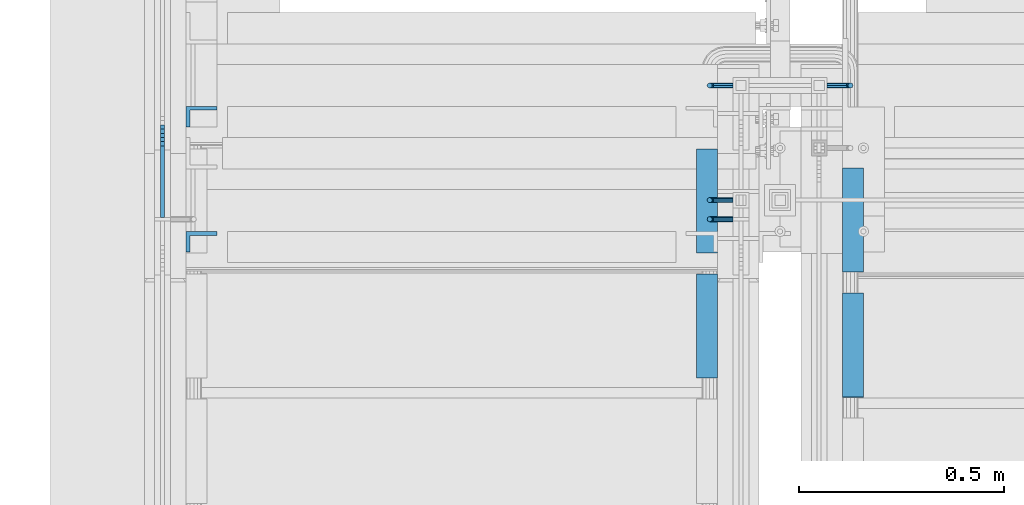
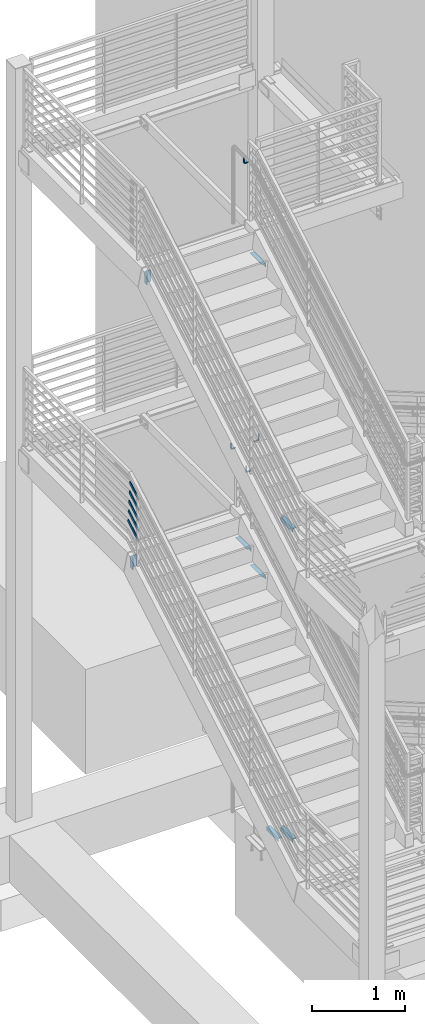
# One storey, part 863 of 1179: 12 beams, 5 members, 10 elements without a shape of their own.
"""IFC2X3 building model written with IfcOpenShell, lengths in millimetres."""

from ifc_helpers import new_model, si_unit, frame, origin_with_axes, place, context, subcontext, project, spatial, faceted_brep, material, type_object, element, aggregate, save


model = new_model("IFC2X3")

# Units and contexts
model_context = context("Model", 3, precision=1e-05, world=origin_with_axes())
body_context = subcontext(model_context, "Body", "Model", "MODEL_VIEW")
ifc_project = project(units=[si_unit("LENGTHUNIT", "METRE", prefix="MILLI"), si_unit("AREAUNIT", "SQUARE_METRE"), si_unit("VOLUMEUNIT", "CUBIC_METRE"), si_unit("MASSUNIT", "GRAM", prefix="KILO"), si_unit("TIMEUNIT", "SECOND"), si_unit("PLANEANGLEUNIT", "RADIAN"), si_unit("SOLIDANGLEUNIT", "STERADIAN"), si_unit("THERMODYNAMICTEMPERATUREUNIT", "DEGREE_CELSIUS"), si_unit("LUMINOUSINTENSITYUNIT", "LUMEN")], contexts=[model_context])

# Site, building, storey
site_placement = place(None, origin_with_axes())
site = spatial("IfcSite", under=ifc_project, at=site_placement, CompositionType="ELEMENT")
building_placement = place(site_placement, origin_with_axes())
building = spatial("IfcBuilding", under=site, at=building_placement, Name="Undefined", CompositionType="ELEMENT")
storey_placement = place(building_placement, origin_with_axes())
storey = spatial("IfcBuildingStorey", under=building, at=storey_placement, Name="Undefined", CompositionType="ELEMENT", Elevation=0.0)

# Assembly, beam
assembly_1_placement = place(storey_placement, origin_with_axes())
assembly_1 = element("IfcElementAssembly", 1, at=assembly_1_placement, inside=storey, Name="STRINGER", AssemblyPlace="NOTDEFINED", PredefinedType="RIGID_FRAME")
ifc_material = material(Name="STEEL/A36")
beam_type_1 = type_object("IfcBeamType", Name="L2X2X3/16", PredefinedType="NOTDEFINED")
beam_1_placement = place(assembly_1_placement, frame((-1930.39999999998, 34935.4643772991, 7889.87499999954), z_axis=(-1.0, 0.0, 0.0), x_axis=(0.0, -1.0, 0.0)))
beam_1 = element("IfcBeam", 2, at=beam_1_placement, type_object=beam_type_1, material=ifc_material, Name="ANGLE", ObjectType="L2X2X3/16", context=body_context, shape_type="Brep", body=[
    faceted_brep([(0.0, 25.3999999999996, -25.4000000000015), (0.0, 25.3999999999996, 25.4000000000015), (254.0, 25.3999999999996, 25.4000000000001), (254.0, 25.3999999999996, -25.4000000000001), (0.0, 20.6374999999998, 25.4000000000015), (254.0, 20.6374999999998, 25.4000000000001), (0.0, 20.6374999999998, -20.6374999999971), (254.0, 20.6374999999998, -20.6374999999998), (0.0, -25.3999999999996, -20.6374999999971), (254.0, -25.3999999999996, -20.6374999999998), (0.0, -25.3999999999996, -25.4000000000015), (254.0, -25.3999999999996, -25.4000000000001)], [[[0, 1, 2, 3]], [[1, 4, 5, 2]], [[4, 6, 7, 5]], [[6, 8, 9, 7]], [[8, 10, 11, 9]], [[10, 0, 3, 11]], [[5, 7, 9, 11, 3, 2]], [[10, 8, 6, 4, 1, 0]]]),
])
aggregate(assembly_1, [beam_1])

assembly_2_placement = place(storey_placement, origin_with_axes())
assembly_2 = element("IfcElementAssembly", 3, at=assembly_2_placement, inside=storey, Name="STRINGER", AssemblyPlace="NOTDEFINED", PredefinedType="RIGID_FRAME")
beam_2_placement = place(assembly_2_placement, frame((-1574.80000000599, 34635.1356222246, 4333.87499890111), z_axis=(1.0, 0.0, 0.0), x_axis=(0.0, 1.0, 0.0)))
beam_2 = element("IfcBeam", 4, at=beam_2_placement, type_object=beam_type_1, material=ifc_material, Name="ANGLE", ObjectType="L2X2X3/16", context=body_context, shape_type="Brep", body=[
    faceted_brep([(0.0, 25.3999999999996, -25.4000000000015), (0.0, 25.3999999999996, 25.4000000000015), (254.0, 25.3999999999996, 25.4000000000001), (254.0, 25.3999999999996, -25.4000000000001), (0.0, 20.6374999999998, 25.4000000000015), (254.0, 20.6374999999998, 25.4000000000001), (0.0, 20.6374999999998, -20.6374999999971), (254.0, 20.6374999999998, -20.6374999999998), (0.0, -25.3999999999996, -20.6374999999971), (254.0, -25.3999999999996, -20.6374999999998), (0.0, -25.3999999999996, -25.4000000000015), (254.0, -25.3999999999996, -25.4000000000001)], [[[0, 1, 2, 3]], [[1, 4, 5, 2]], [[4, 6, 7, 5]], [[6, 8, 9, 7]], [[8, 10, 11, 9]], [[10, 0, 3, 11]], [[5, 7, 9, 11, 3, 2]], [[10, 8, 6, 4, 1, 0]]]),
])
aggregate(assembly_2, [beam_2])

# Assembly, beams
assembly_3_placement = place(storey_placement, origin_with_axes())
assembly_3 = element("IfcElementAssembly", 5, at=assembly_3_placement, inside=storey, Name="STRINGER", AssemblyPlace="NOTDEFINED", PredefinedType="RIGID_FRAME")
beam_3_placement = place(assembly_3_placement, frame((-1574.79999997938, 34635.0824003931, 273.583977467917), z_axis=(1.0, 0.0, 0.0), x_axis=(0.0, 1.0, 0.0)))
beam_3 = element("IfcBeam", 6, at=beam_3_placement, type_object=beam_type_1, material=ifc_material, Name="ANGLE", ObjectType="L2X2X3/16", context=body_context, shape_type="Brep", body=[
    faceted_brep([(0.0, 25.3999999999996, -25.4000000000015), (0.0, 25.3999999999996, 25.4000000000015), (254.0, 25.3999999999996, 25.4000000000001), (254.0, 25.3999999999996, -25.4000000000001), (0.0, 20.6374999999998, 25.4000000000015), (254.0, 20.6374999999998, 25.4000000000001), (0.0, 20.6374999999998, -20.6374999999971), (254.0, 20.6374999999998, -20.6374999999998), (0.0, -25.3999999999996, -20.6374999999971), (254.0, -25.3999999999996, -20.6374999999998), (0.0, -25.3999999999996, -25.4000000000015), (254.0, -25.3999999999996, -25.4000000000001)], [[[0, 1, 2, 3]], [[1, 4, 5, 2]], [[4, 6, 7, 5]], [[6, 8, 9, 7]], [[8, 10, 11, 9]], [[10, 0, 3, 11]], [[5, 7, 9, 11, 3, 2]], [[10, 8, 6, 4, 1, 0]]]),
])
beam_4_placement = place(assembly_3_placement, frame((-1574.79999997934, 34939.8825541272, 97.102083330775), z_axis=(1.0, 0.0, 0.0), x_axis=(0.0, 1.0, 0.0)))
beam_4 = element("IfcBeam", 7, at=beam_4_placement, type_object=beam_type_1, material=ifc_material, Name="ANGLE", ObjectType="L2X2X3/16", context=body_context, shape_type="Brep", body=[
    faceted_brep([(0.0, 25.3999999999996, -25.4000000000015), (0.0, 25.3999999999996, 25.4000000000015), (254.0, 25.3999999999996, 25.4000000000001), (254.0, 25.3999999999996, -25.4000000000001), (0.0, 20.6374999999998, 25.4000000000015), (254.0, 20.6374999999998, 25.4000000000001), (0.0, 20.6374999999998, -20.6374999999971), (254.0, 20.6374999999998, -20.6374999999998), (0.0, -25.3999999999996, -20.6374999999971), (254.0, -25.3999999999996, -20.6374999999998), (0.0, -25.3999999999996, -25.4000000000015), (254.0, -25.3999999999996, -25.4000000000001)], [[[0, 1, 2, 3]], [[1, 4, 5, 2]], [[4, 6, 7, 5]], [[6, 8, 9, 7]], [[8, 10, 11, 9]], [[10, 0, 3, 11]], [[5, 7, 9, 11, 3, 2]], [[10, 8, 6, 4, 1, 0]]]),
])
aggregate(assembly_3, [beam_3, beam_4])

assembly_4_placement = place(storey_placement, origin_with_axes())
assembly_4 = element("IfcElementAssembly", 8, at=assembly_4_placement, inside=storey, Name="STRINGER", AssemblyPlace="NOTDEFINED", PredefinedType="RIGID_FRAME")
beam_5_placement = place(assembly_4_placement, frame((-1930.40000000084, 35240.3192612356, 3979.59791666724), z_axis=(-1.0, 0.0, 0.0), x_axis=(0.0, -1.0, 0.0)))
beam_5 = element("IfcBeam", 9, at=beam_5_placement, type_object=beam_type_1, material=ifc_material, Name="ANGLE", ObjectType="L2X2X3/16", context=body_context, shape_type="Brep", body=[
    faceted_brep([(0.0, 25.3999999999996, -25.4000000000015), (0.0, 25.3999999999996, 25.4000000000015), (254.0, 25.3999999999996, 25.4000000000001), (254.0, 25.3999999999996, -25.4000000000001), (0.0, 20.6374999999998, 25.4000000000015), (254.0, 20.6374999999998, 25.4000000000001), (0.0, 20.6374999999998, -20.6374999999971), (254.0, 20.6374999999998, -20.6374999999998), (0.0, -25.3999999999996, -20.6374999999971), (254.0, -25.3999999999996, -20.6374999999998), (0.0, -25.3999999999996, -25.4000000000015), (254.0, -25.3999999999996, -25.4000000000001)], [[[0, 1, 2, 3]], [[1, 4, 5, 2]], [[4, 6, 7, 5]], [[6, 8, 9, 7]], [[8, 10, 11, 9]], [[10, 0, 3, 11]], [[5, 7, 9, 11, 3, 2]], [[10, 8, 6, 4, 1, 0]]]),
])
beam_6_placement = place(assembly_4_placement, frame((-1930.40000000084, 34935.5192613248, 3803.12083333391), z_axis=(-1.0, 0.0, 0.0), x_axis=(0.0, -1.0, 0.0)))
beam_6 = element("IfcBeam", 10, at=beam_6_placement, type_object=beam_type_1, material=ifc_material, Name="ANGLE", ObjectType="L2X2X3/16", context=body_context, shape_type="Brep", body=[
    faceted_brep([(0.0, 25.3999999999996, -25.4000000000015), (0.0, 25.3999999999996, 25.4000000000015), (254.0, 25.3999999999996, 25.4000000000001), (254.0, 25.3999999999996, -25.4000000000001), (0.0, 20.6374999999998, 25.4000000000015), (254.0, 20.6374999999998, 25.4000000000001), (0.0, 20.6374999999998, -20.6374999999971), (254.0, 20.6374999999998, -20.6374999999998), (0.0, -25.3999999999996, -20.6374999999971), (254.0, -25.3999999999996, -20.6374999999998), (0.0, -25.3999999999996, -25.4000000000015), (254.0, -25.3999999999996, -25.4000000000001)], [[[0, 1, 2, 3]], [[1, 4, 5, 2]], [[4, 6, 7, 5]], [[6, 8, 9, 7]], [[8, 10, 11, 9]], [[10, 0, 3, 11]], [[5, 7, 9, 11, 3, 2]], [[10, 8, 6, 4, 1, 0]]]),
])
aggregate(assembly_4, [beam_5, beam_6])

assembly_5_placement = place(storey_placement, origin_with_axes())
assembly_5 = element("IfcElementAssembly", 11, at=assembly_5_placement, inside=storey, Name="GUARDRAIL", AssemblyPlace="NOTDEFINED", PredefinedType="RIGID_FRAME")
beam_type_2 = type_object("IfcBeamType", PredefinedType="NOTDEFINED")
beam_7_placement = place(assembly_5_placement, frame((-1866.89999778751, 35068.9333345709, 4951.14339589579), z_axis=(0.0, 0.0, 1.0), x_axis=(-1.0, 0.0, 0.0)))
beam_7 = element("IfcBeam", 12, at=beam_7_placement, type_object=beam_type_2, material=ifc_material, Name="BRACKET", context=body_context, shape_type="Brep", body=[
    faceted_brep([(0.0, -4.49012806053361, 4.49012806053452), (0.0, 0.0, 6.34999999999991), (0.0, 4.49012806053361, 4.49012806053452), (0.0, 6.34999999999854, 0.0), (0.0, 4.49012806053361, -4.49012806053452), (0.0, 0.0, -6.34999999999991), (0.0, -4.49012806053361, -4.49012806053452), (0.0, -6.34999999999854, 0.0), (44.4500031699827, 0.0, -6.34999999999991), (44.4500031699827, -4.49012806053361, -4.49012806053452), (44.4500031699827, -6.34999999999854, 2.19733919948339e-09), (44.4500031699827, -4.49012806053361, 4.49012806053452), (44.4500031699827, 0.0, 6.34999999999991), (44.4500031699827, 4.49012806053361, 4.49012806053452), (44.4500031699827, 6.34999999999854, 0.0), (44.4500031699827, 4.49012806053361, -4.49012806053452), (53.0450671075391, 4.4901280570557, -2.18708762112465), (53.97500307462, -4.32919478043914e-09, -3.79778396764459), (53.0450671022344, -4.49012806401151, -2.1870876194389), (50.8000030708674, -6.35000000142099, 1.70147734757802), (48.5549390416977, -4.4901280599006, 5.59004231389645), (47.6250030746168, 1.48793333210051e-09, 7.20073866041594), (48.5549390470023, 4.49012806117025, 5.5900423122107), (50.8000030783693, 6.34999999857973, 1.70147734519378), (55.4485256393576, 6.34999999469437, 6.34999990618098), (59.337090604122, 4.49012805180246, 4.10493587545716), (51.5599606707875, 4.49012805866005, 8.59506393599531), (49.9492643188311, -4.54747350886464e-10, 9.52499990463002), (51.5599606615996, -4.4901280624108, 8.59506393379797), (55.4485256263639, -6.35000000530636, 6.34999990307369), (59.337090594938, -4.49012806926839, 4.10493587326664), (60.9477869468905, -1.0153598850593e-08, 3.17499990462466), (61.6401310450869, 4.49012804462109, 12.6999998130159), (63.5000029792477, -1.81098585017025e-08, 12.6999998092651), (57.1500029867496, 6.3499999893902, 12.6999998145698), (52.6598749240178, 4.49012805522943, 12.6999998130159), (50.8000029792477, -3.10683390125632e-09, 12.6999998092651), (52.6598749134085, -4.49012806583778, 12.6999998055144), (57.1500029739432, -6.35000001061053, 12.6999998039605), (61.6401310344776, -4.49012807644976, 12.6999998055144), (63.5000029792478, -6.94672053214163e-08, 76.1999999999989), (61.6401296126592, -4.49012700571984, 78.799752974352), (57.1500015702397, -6.34999899351169, 79.8766059398226), (52.6598734915901, -4.49012712951662, 78.7997530460293), (50.8000029792478, -5.78438630327582e-08, 76.1999999999989), (52.6598733663686, 4.49012892461178, 73.6002471520565), (57.1500014002565, 6.35000091383336, 72.5233941857605), (61.6401294874379, 4.49012905126074, 73.6002470787289)], [[[0, 1, 2, 3, 4, 5, 6, 7]], [[6, 5, 8, 9]], [[7, 6, 9, 10]], [[0, 7, 10, 11]], [[1, 0, 11, 12]], [[2, 1, 12, 13]], [[3, 2, 13, 14]], [[4, 3, 14, 15]], [[5, 4, 15, 8]], [[8, 15, 16, 17]], [[9, 8, 17, 18]], [[10, 9, 18, 19]], [[11, 10, 19, 20]], [[12, 11, 20, 21]], [[13, 12, 21, 22]], [[14, 13, 22, 23]], [[15, 14, 23, 16]], [[23, 24, 25, 16]], [[22, 26, 24, 23]], [[21, 27, 26, 22]], [[20, 28, 27, 21]], [[19, 29, 28, 20]], [[18, 30, 29, 19]], [[17, 31, 30, 18]], [[16, 25, 31, 17]], [[25, 32, 33, 31]], [[24, 34, 32, 25]], [[26, 35, 34, 24]], [[27, 36, 35, 26]], [[28, 37, 36, 27]], [[29, 38, 37, 28]], [[30, 39, 38, 29]], [[31, 33, 39, 30]], [[39, 33, 40, 41]], [[38, 39, 41, 42]], [[37, 38, 42, 43]], [[36, 37, 43, 44]], [[35, 36, 44, 45]], [[34, 35, 45, 46]], [[32, 34, 46, 47]], [[33, 32, 47, 40]], [[46, 45, 44, 43, 42, 41, 40, 47]]]),
])
beam_8_placement = place(assembly_5_placement, frame((-1866.89999778751, 35394.9000007138, 5054.60000427237), z_axis=(0.0, 0.0, 1.0), x_axis=(-1.0, 0.0, 0.0)))
beam_8 = element("IfcBeam", 13, at=beam_8_placement, type_object=beam_type_2, material=ifc_material, Name="BRACKET", context=body_context, shape_type="Brep", body=[
    faceted_brep([(0.0, -4.49012806053361, 4.49012806053452), (0.0, 0.0, 6.34999999999991), (0.0, 4.49012806053361, 4.49012806053452), (0.0, 6.34999999999854, 0.0), (0.0, 4.49012806053361, -4.49012806053452), (0.0, 0.0, -6.34999999999991), (0.0, -4.49012806053361, -4.49012806053452), (0.0, -6.34999999999854, 0.0), (44.4500031699827, 0.0, -6.34999999999991), (44.4500031699827, -4.49012806053361, -4.49012806053452), (44.4500031699827, -6.34999999999854, 2.19733919948339e-09), (44.4500031699827, -4.49012806053361, 4.49012806053452), (44.4500031699827, 0.0, 6.34999999999991), (44.4500031699827, 4.49012806053361, 4.49012806053452), (44.4500031699827, 6.34999999999854, 0.0), (44.4500031699827, 4.49012806053361, -4.49012806053452), (53.0450671075391, 4.4901280570557, -2.18708762112465), (53.97500307462, -4.32919478043914e-09, -3.79778396764459), (53.0450671022344, -4.49012806401151, -2.1870876194389), (50.8000030708674, -6.35000000142099, 1.70147734757802), (48.5549390416977, -4.4901280599006, 5.59004231389645), (47.6250030746168, 1.48793333210051e-09, 7.20073866041594), (48.5549390470023, 4.49012806117025, 5.5900423122107), (50.8000030783693, 6.34999999857973, 1.70147734519378), (55.4485256393576, 6.34999999469437, 6.34999990618098), (59.337090604122, 4.49012805180246, 4.10493587545716), (51.5599606707875, 4.49012805866005, 8.59506393599531), (49.9492643188311, -4.54747350886464e-10, 9.52499990463002), (51.5599606615996, -4.4901280624108, 8.59506393379797), (55.4485256263639, -6.35000000530636, 6.34999990307369), (59.337090594938, -4.49012806926839, 4.10493587326664), (60.9477869468905, -1.0153598850593e-08, 3.17499990462466), (61.6401310450869, 4.49012804462109, 12.6999998130159), (63.5000029792477, -1.81098585017025e-08, 12.6999998092651), (57.1500029867496, 6.3499999893902, 12.6999998145698), (52.6598749240178, 4.49012805522943, 12.6999998130159), (50.8000029792477, -3.10683390125632e-09, 12.6999998092651), (52.6598749134085, -4.49012806583778, 12.6999998055144), (57.1500029739432, -6.35000001061053, 12.6999998039605), (61.6401310344776, -4.49012807644976, 12.6999998055144), (63.5000029792478, -6.94672053214163e-08, 76.1999999999989), (61.6401310356729, -4.49012812829824, 76.1999999999989), (57.1500029739432, -6.3500000636559, 76.1999999999989), (52.6598749146037, -4.49012812008004, 76.1999999999989), (50.8000029792478, -5.78438630327582e-08, 76.1999999999989), (52.6598749228227, 4.49012800098717, 76.1999999999989), (57.1500029850595, 6.34999993634483, 76.1999999999989), (61.6401310438919, 4.49012799276898, 76.1999999999989)], [[[0, 1, 2, 3, 4, 5, 6, 7]], [[6, 5, 8, 9]], [[7, 6, 9, 10]], [[0, 7, 10, 11]], [[1, 0, 11, 12]], [[2, 1, 12, 13]], [[3, 2, 13, 14]], [[4, 3, 14, 15]], [[5, 4, 15, 8]], [[8, 15, 16, 17]], [[9, 8, 17, 18]], [[10, 9, 18, 19]], [[11, 10, 19, 20]], [[12, 11, 20, 21]], [[13, 12, 21, 22]], [[14, 13, 22, 23]], [[15, 14, 23, 16]], [[23, 24, 25, 16]], [[22, 26, 24, 23]], [[21, 27, 26, 22]], [[20, 28, 27, 21]], [[19, 29, 28, 20]], [[18, 30, 29, 19]], [[17, 31, 30, 18]], [[16, 25, 31, 17]], [[25, 32, 33, 31]], [[24, 34, 32, 25]], [[26, 35, 34, 24]], [[27, 36, 35, 26]], [[28, 37, 36, 27]], [[29, 38, 37, 28]], [[30, 39, 38, 29]], [[31, 33, 39, 30]], [[39, 33, 40, 41]], [[38, 39, 41, 42]], [[37, 38, 42, 43]], [[36, 37, 43, 44]], [[35, 36, 44, 45]], [[34, 35, 45, 46]], [[32, 34, 46, 47]], [[33, 32, 47, 40]], [[46, 45, 44, 43, 42, 41, 40, 47]]]),
])
aggregate(assembly_5, [beam_7, beam_8])

# Assembly, beam
assembly_6_placement = place(storey_placement, origin_with_axes())
assembly_6 = element("IfcElementAssembly", 14, at=assembly_6_placement, inside=storey, Name="GUARDRAIL", AssemblyPlace="NOTDEFINED", PredefinedType="RIGID_FRAME")
beam_9_placement = place(assembly_6_placement, frame((-1866.89999629849, 35115.5000012637, 8966.20000000065), z_axis=(0.0, 0.0, 1.0), x_axis=(-1.0, 0.0, 0.0)))
beam_9 = element("IfcBeam", 15, at=beam_9_placement, type_object=beam_type_2, material=ifc_material, Name="BRACKET", context=body_context, shape_type="Brep", body=[
    faceted_brep([(0.0, -4.49012806053361, 4.49012806053452), (0.0, 0.0, 6.34999999999991), (0.0, 4.49012806053361, 4.49012806053452), (0.0, 6.34999999999854, 0.0), (0.0, 4.49012806053361, -4.49012806053452), (0.0, 0.0, -6.34999999999991), (0.0, -4.49012806053361, -4.49012806053452), (0.0, -6.34999999999854, 0.0), (44.4500031699827, 0.0, -6.34999999999991), (44.4500031699827, -4.49012806053361, -4.49012806053452), (44.4500031699827, -6.34999999999854, 2.19733919948339e-09), (44.4500031699827, -4.49012806053361, 4.49012806053452), (44.4500031699827, 0.0, 6.34999999999991), (44.4500031699827, 4.49012806053361, 4.49012806053452), (44.4500031699827, 6.34999999999854, 0.0), (44.4500031699827, 4.49012806053361, -4.49012806053452), (53.0450671075391, 4.4901280570557, -2.18708762112465), (53.97500307462, -4.32919478043914e-09, -3.79778396764459), (53.0450671022344, -4.49012806401151, -2.1870876194389), (50.8000030708674, -6.35000000142099, 1.70147734757802), (48.5549390416977, -4.4901280599006, 5.59004231389645), (47.6250030746168, 1.48793333210051e-09, 7.20073866041594), (48.5549390470023, 4.49012806117025, 5.5900423122107), (50.8000030783693, 6.34999999857973, 1.70147734519378), (55.4485256393576, 6.34999999469437, 6.34999990618098), (59.337090604122, 4.49012805180246, 4.10493587545716), (51.5599606707875, 4.49012805866005, 8.59506393599531), (49.9492643188311, -4.54747350886464e-10, 9.52499990463002), (51.5599606615996, -4.4901280624108, 8.59506393379797), (55.4485256263639, -6.35000000530636, 6.34999990307369), (59.337090594938, -4.49012806926839, 4.10493587326664), (60.9477869468905, -1.0153598850593e-08, 3.17499990462466), (61.6401310450869, 4.49012804462109, 12.6999998130159), (63.5000029792477, -1.81098585017025e-08, 12.6999998092651), (57.1500029867496, 6.3499999893902, 12.6999998145698), (52.6598749240178, 4.49012805522943, 12.6999998130159), (50.8000029792477, -3.10683390125632e-09, 12.6999998092651), (52.6598749134085, -4.49012806583778, 12.6999998055144), (57.1500029739432, -6.35000001061053, 12.6999998039605), (61.6401310344776, -4.49012807644976, 12.6999998055144), (63.5000029792478, -6.94672053214163e-08, 76.1999999999989), (61.6401310356729, -4.49012812829824, 76.1999999999989), (57.1500029739432, -6.3500000636559, 76.1999999999989), (52.6598749146037, -4.49012812008004, 76.1999999999989), (50.8000029792478, -5.78438630327582e-08, 76.1999999999989), (52.6598749228227, 4.49012800098717, 76.1999999999989), (57.1500029850595, 6.34999993634483, 76.1999999999989), (61.6401310438919, 4.49012799276898, 76.1999999999989)], [[[0, 1, 2, 3, 4, 5, 6, 7]], [[6, 5, 8, 9]], [[7, 6, 9, 10]], [[0, 7, 10, 11]], [[1, 0, 11, 12]], [[2, 1, 12, 13]], [[3, 2, 13, 14]], [[4, 3, 14, 15]], [[5, 4, 15, 8]], [[8, 15, 16, 17]], [[9, 8, 17, 18]], [[10, 9, 18, 19]], [[11, 10, 19, 20]], [[12, 11, 20, 21]], [[13, 12, 21, 22]], [[14, 13, 22, 23]], [[15, 14, 23, 16]], [[23, 24, 25, 16]], [[22, 26, 24, 23]], [[21, 27, 26, 22]], [[20, 28, 27, 21]], [[19, 29, 28, 20]], [[18, 30, 29, 19]], [[17, 31, 30, 18]], [[16, 25, 31, 17]], [[25, 32, 33, 31]], [[24, 34, 32, 25]], [[26, 35, 34, 24]], [[27, 36, 35, 26]], [[28, 37, 36, 27]], [[29, 38, 37, 28]], [[30, 39, 38, 29]], [[31, 33, 39, 30]], [[39, 33, 40, 41]], [[38, 39, 41, 42]], [[37, 38, 42, 43]], [[36, 37, 43, 44]], [[35, 36, 44, 45]], [[34, 35, 45, 46]], [[32, 34, 46, 47]], [[33, 32, 47, 40]], [[46, 45, 44, 43, 42, 41, 40, 47]]]),
])
aggregate(assembly_6, [beam_9])

assembly_7_placement = place(storey_placement, origin_with_axes())
assembly_7 = element("IfcElementAssembly", 16, at=assembly_7_placement, inside=storey, Name="GUARDRAIL", AssemblyPlace="NOTDEFINED", PredefinedType="RIGID_FRAME")
beam_10_placement = place(assembly_7_placement, frame((-1638.3000007445, 35394.9000006757, 5054.60000181303), z_axis=(0.0, 0.0, 1.0), x_axis=(1.0, 0.0, 0.0)))
beam_10 = element("IfcBeam", 17, at=beam_10_placement, type_object=beam_type_2, material=ifc_material, Name="BRACKET", context=body_context, shape_type="Brep", body=[
    faceted_brep([(0.0, -4.49012806053361, 4.49012806053452), (0.0, 0.0, 6.34999999999991), (0.0, 4.49012806053361, 4.49012806053452), (0.0, 6.34999999999854, 0.0), (0.0, 4.49012806053361, -4.49012806053452), (0.0, 0.0, -6.34999999999991), (0.0, -4.49012806053361, -4.49012806053452), (0.0, -6.34999999999854, 0.0), (44.4500031699827, 0.0, -6.34999999999991), (44.4500031699827, -4.49012806053361, -4.49012806053452), (44.4500031699827, -6.34999999999854, 2.19733919948339e-09), (44.4500031699827, -4.49012806053361, 4.49012806053452), (44.4500031699827, 0.0, 6.34999999999991), (44.4500031699827, 4.49012806053361, 4.49012806053452), (44.4500031699827, 6.34999999999854, 0.0), (44.4500031699827, 4.49012806053361, -4.49012806053452), (53.0450671075391, 4.4901280570557, -2.18708762112465), (53.97500307462, -4.32919478043914e-09, -3.79778396764459), (53.0450671022344, -4.49012806401151, -2.1870876194389), (50.8000030708674, -6.35000000142099, 1.70147734757802), (48.5549390416977, -4.4901280599006, 5.59004231389645), (47.6250030746168, 1.48793333210051e-09, 7.20073866041594), (48.5549390470023, 4.49012806117025, 5.5900423122107), (50.8000030783693, 6.34999999857973, 1.70147734519378), (55.4485256393576, 6.34999999469437, 6.34999990618098), (59.337090604122, 4.49012805180246, 4.10493587545716), (51.5599606707875, 4.49012805866005, 8.59506393599531), (49.9492643188311, -4.54747350886464e-10, 9.52499990463002), (51.5599606615996, -4.4901280624108, 8.59506393379797), (55.4485256263639, -6.35000000530636, 6.34999990307369), (59.337090594938, -4.49012806926839, 4.10493587326664), (60.9477869468905, -1.0153598850593e-08, 3.17499990462466), (61.6401310450869, 4.49012804462109, 12.6999998130159), (63.5000029792477, -1.81098585017025e-08, 12.6999998092651), (57.1500029867496, 6.3499999893902, 12.6999998145698), (52.6598749240178, 4.49012805522943, 12.6999998130159), (50.8000029792477, -3.10683390125632e-09, 12.6999998092651), (52.6598749134085, -4.49012806583778, 12.6999998055144), (57.1500029739432, -6.35000001061053, 12.6999998039605), (61.6401310344776, -4.49012807644976, 12.6999998055144), (63.5000029792478, -6.94672053214163e-08, 76.1999999999989), (61.6401310356729, -4.49012812829824, 76.1999999999989), (57.1500029739432, -6.3500000636559, 76.1999999999989), (52.6598749146037, -4.49012812008004, 76.1999999999989), (50.8000029792478, -5.78438630327582e-08, 76.1999999999989), (52.6598749228227, 4.49012800098717, 76.1999999999989), (57.1500029850595, 6.34999993634483, 76.1999999999989), (61.6401310438919, 4.49012799276898, 76.1999999999989)], [[[0, 1, 2, 3, 4, 5, 6, 7]], [[6, 5, 8, 9]], [[7, 6, 9, 10]], [[0, 7, 10, 11]], [[1, 0, 11, 12]], [[2, 1, 12, 13]], [[3, 2, 13, 14]], [[4, 3, 14, 15]], [[5, 4, 15, 8]], [[8, 15, 16, 17]], [[9, 8, 17, 18]], [[10, 9, 18, 19]], [[11, 10, 19, 20]], [[12, 11, 20, 21]], [[13, 12, 21, 22]], [[14, 13, 22, 23]], [[15, 14, 23, 16]], [[23, 24, 25, 16]], [[22, 26, 24, 23]], [[21, 27, 26, 22]], [[20, 28, 27, 21]], [[19, 29, 28, 20]], [[18, 30, 29, 19]], [[17, 31, 30, 18]], [[16, 25, 31, 17]], [[25, 32, 33, 31]], [[24, 34, 32, 25]], [[26, 35, 34, 24]], [[27, 36, 35, 26]], [[28, 37, 36, 27]], [[29, 38, 37, 28]], [[30, 39, 38, 29]], [[31, 33, 39, 30]], [[39, 33, 40, 41]], [[38, 39, 41, 42]], [[37, 38, 42, 43]], [[36, 37, 43, 44]], [[35, 36, 44, 45]], [[34, 35, 45, 46]], [[32, 34, 46, 47]], [[33, 32, 47, 40]], [[46, 45, 44, 43, 42, 41, 40, 47]]]),
])
aggregate(assembly_7, [beam_10])

# Assembly, members
assembly_8_placement = place(storey_placement, origin_with_axes())
assembly_8 = element("IfcElementAssembly", 18, at=assembly_8_placement, inside=storey, Name="GUARDRAIL", AssemblyPlace="NOTDEFINED", PredefinedType="RIGID_FRAME")
member_type = type_object("IfcMemberType", PredefinedType="NOTDEFINED")
member_1_placement = place(assembly_8_placement, frame((-3257.54999923555, 35306.2109559658, 4661.81110712449), z_axis=(0.0, -0.501065882891537, 0.865409140812671), x_axis=(0.0, -0.86540914081267, -0.501065882891538)))
member_1 = element("IfcMember", 19, at=member_1_placement, type_object=member_type, material=ifc_material, Name="PLATE", context=body_context, shape_type="Brep", body=[
    faceted_brep([(19.5362428415756, 4.76249999999982, -19.0500000000156), (9.30223585410567, 4.76249999999982, 19.0499999999756), (257.646709569875, 4.76250000000005, 19.0499999996373), (279.70634499297, 4.76250000000005, -19.0500000003703), (9.30223585410567, -4.76249999999982, 19.0499999999756), (257.646709569875, -4.76250000000005, 19.0499999996373), (19.5362428415756, -4.76249999999982, -19.0500000000156), (279.70634499297, -4.76250000000005, -19.0500000003703)], [[[0, 1, 2, 3]], [[1, 4, 5, 2]], [[4, 6, 7, 5]], [[6, 0, 3, 7]], [[5, 7, 3, 2]], [[6, 4, 1, 0]]]),
])
member_2_placement = place(assembly_8_placement, frame((-3257.54999923555, 35295.2436396223, 4791.5615260891), z_axis=(0.0, -0.501065882891537, 0.865409140812671), x_axis=(0.0, -0.86540914081267, -0.501065882891538)))
member_2 = element("IfcMember", 20, at=member_2_placement, type_object=member_type, material=ifc_material, Name="PLATE", context=body_context, shape_type="Brep", body=[
    faceted_brep([(18.6888871347473, 4.76249999999982, -19.0500000000193), (8.45488014727744, 4.76249999999982, 19.0499999999738), (244.97372539834, 4.76250000000005, 19.0499999996537), (267.033360821439, 4.76250000000005, -19.0500000003558), (8.45488014727744, -4.76249999999982, 19.0499999999738), (244.97372539834, -4.76250000000005, 19.0499999996537), (18.6888871347473, -4.76249999999982, -19.0500000000193), (267.033360821439, -4.76250000000005, -19.0500000003558)], [[[0, 1, 2, 3]], [[1, 4, 5, 2]], [[4, 6, 7, 5]], [[6, 0, 3, 7]], [[5, 7, 3, 2]], [[6, 4, 1, 0]]]),
])
member_3_placement = place(assembly_8_placement, frame((-3257.54999923555, 35284.2763232849, 4921.31194504548), z_axis=(0.0, -0.501065882891537, 0.865409140812671), x_axis=(0.0, -0.86540914081267, -0.501065882891538)))
member_3 = element("IfcMember", 21, at=member_3_placement, type_object=member_type, material=ifc_material, Name="PLATE", context=body_context, shape_type="Brep", body=[
    faceted_brep([(17.8415314115118, 4.76249999999982, -19.0500000000102), (7.60752442403464, 4.76249999999982, 19.0499999999774), (232.300741233827, 4.76250000000005, 19.0499999996664), (254.360376656929, 4.76250000000005, -19.0500000003394), (7.60752442403464, -4.76249999999982, 19.0499999999774), (232.300741233827, -4.76250000000005, 19.0499999996664), (17.8415314115118, -4.76249999999982, -19.0500000000102), (254.360376656929, -4.76250000000005, -19.0500000003394)], [[[0, 1, 2, 3]], [[1, 4, 5, 2]], [[4, 6, 7, 5]], [[6, 0, 3, 7]], [[5, 7, 3, 2]], [[6, 4, 1, 0]]]),
])
member_4_placement = place(assembly_8_placement, frame((-3257.54999923555, 35273.3090069408, 5051.06236400648), z_axis=(0.0, -0.501065882891537, 0.865409140812671), x_axis=(0.0, -0.86540914081267, -0.501065882891538)))
member_4 = element("IfcMember", 22, at=member_4_placement, type_object=member_type, material=ifc_material, Name="PLATE", context=body_context, shape_type="Brep", body=[
    faceted_brep([(16.9941756974658, 4.76249999999982, -19.050000000012), (6.76016870999592, 4.76249999999982, 19.0499999999774), (219.627757061375, 4.76250000000005, 19.0499999996864), (241.687392484477, 4.76250000000005, -19.0500000003194), (6.76016870999592, -4.76249999999982, 19.0499999999774), (219.627757061375, -4.76250000000005, 19.0499999996864), (16.9941756974658, -4.76249999999982, -19.050000000012), (241.687392484477, -4.76250000000005, -19.0500000003194)], [[[0, 1, 2, 3]], [[1, 4, 5, 2]], [[4, 6, 7, 5]], [[6, 0, 3, 7]], [[5, 7, 3, 2]], [[6, 4, 1, 0]]]),
])
member_5_placement = place(assembly_8_placement, frame((-3257.54999923555, 35262.3416905815, 5180.81278297099), z_axis=(0.0, -0.501065882891537, 0.865409140812671), x_axis=(0.0, -0.86540914081267, -0.501065882891538)))
member_5 = element("IfcMember", 23, at=member_5_placement, type_object=member_type, material=ifc_material, Name="PLATE", context=body_context, shape_type="Brep", body=[
    faceted_brep([(16.1468200010422, 4.76249999999982, -19.0500000000138), (5.9128130135723, 4.76249999999982, 19.0499999999774), (206.954772870136, 4.76250000000005, 19.0499999997046), (229.014408293231, 4.76250000000005, -19.0500000003049), (5.9128130135723, -4.76249999999982, 19.0499999999774), (206.954772870136, -4.76250000000005, 19.0499999997046), (16.1468200010422, -4.76249999999982, -19.0500000000138), (229.014408293231, -4.76250000000005, -19.0500000003049)], [[[0, 1, 2, 3]], [[1, 4, 5, 2]], [[4, 6, 7, 5]], [[6, 0, 3, 7]], [[5, 7, 3, 2]], [[6, 4, 1, 0]]]),
])
aggregate(assembly_8, [member_1, member_2, member_3, member_4, member_5])

# Assembly, beam
assembly_9_placement = place(storey_placement, origin_with_axes())
assembly_9 = element("IfcElementAssembly", 24, at=assembly_9_placement, inside=storey, Name="ANGLE", AssemblyPlace="NOTDEFINED", PredefinedType="RIGID_FRAME")
beam_type_3 = type_object("IfcBeamType", Name="L3X2X3/8", PredefinedType="NOTDEFINED")
beam_11_placement = place(assembly_9_placement, frame((-3162.29999999006, 35013.9000000008, 8045.45), z_axis=(1.0, 0.0, 0.0), x_axis=(0.0, 0.0, -1.0)))
beam_11 = element("IfcBeam", 25, at=beam_11_placement, type_object=beam_type_3, material=ifc_material, Name="ANGLE", ObjectType="L3X2X3/8", context=body_context, shape_type="Brep", body=[
    faceted_brep([(0.0, 25.4000000000015, -38.0999999999999), (0.0, 25.4000000000015, 38.0999999999999), (152.4, 25.4000000000015, 38.0999999999999), (152.4, 25.4000000000015, -38.0999999999999), (0.0, 15.875, 38.0999999999999), (152.4, 15.875, 38.0999999999999), (0.0, 15.875, -28.575), (152.4, 15.875, -28.575), (0.0, -25.4000000000015, -28.575), (152.4, -25.4000000000015, -28.575), (0.0, -25.4000000000015, -38.0999999999999), (152.4, -25.4000000000015, -38.0999999999999)], [[[0, 1, 2, 3]], [[1, 4, 5, 2]], [[4, 6, 7, 5]], [[6, 8, 9, 7]], [[8, 10, 11, 9]], [[10, 0, 3, 11]], [[5, 7, 9, 11, 3, 2]], [[10, 8, 6, 4, 1, 0]]]),
])
aggregate(assembly_9, [beam_11])

assembly_10_placement = place(storey_placement, origin_with_axes())
assembly_10 = element("IfcElementAssembly", 26, at=assembly_10_placement, inside=storey, Name="ANGLE", AssemblyPlace="NOTDEFINED", PredefinedType="RIGID_FRAME")
beam_12_placement = place(assembly_10_placement, frame((-3162.29999999006, 35318.7000000027, 4133.85), z_axis=(1.0, 0.0, 0.0), x_axis=(0.0, 0.0, -1.0)))
beam_12 = element("IfcBeam", 27, at=beam_12_placement, type_object=beam_type_3, material=ifc_material, Name="ANGLE", ObjectType="L3X2X3/8", context=body_context, shape_type="Brep", body=[
    faceted_brep([(0.0, 25.4000000000015, -38.0999999999999), (0.0, 25.4000000000015, 38.0999999999999), (152.4, 25.4000000000015, 38.0999999999999), (152.4, 25.4000000000015, -38.0999999999999), (0.0, 15.875, 38.0999999999999), (152.4, 15.875, 38.0999999999999), (0.0, 15.875, -28.575), (152.4, 15.875, -28.575), (0.0, -25.4000000000015, -28.575), (152.4, -25.4000000000015, -28.575), (0.0, -25.4000000000015, -38.0999999999999), (152.4, -25.4000000000015, -38.0999999999999)], [[[0, 1, 2, 3]], [[1, 4, 5, 2]], [[4, 6, 7, 5]], [[6, 8, 9, 7]], [[8, 10, 11, 9]], [[10, 0, 3, 11]], [[5, 7, 9, 11, 3, 2]], [[10, 8, 6, 4, 1, 0]]]),
])
aggregate(assembly_10, [beam_12])

save(model, "model.ifc")
